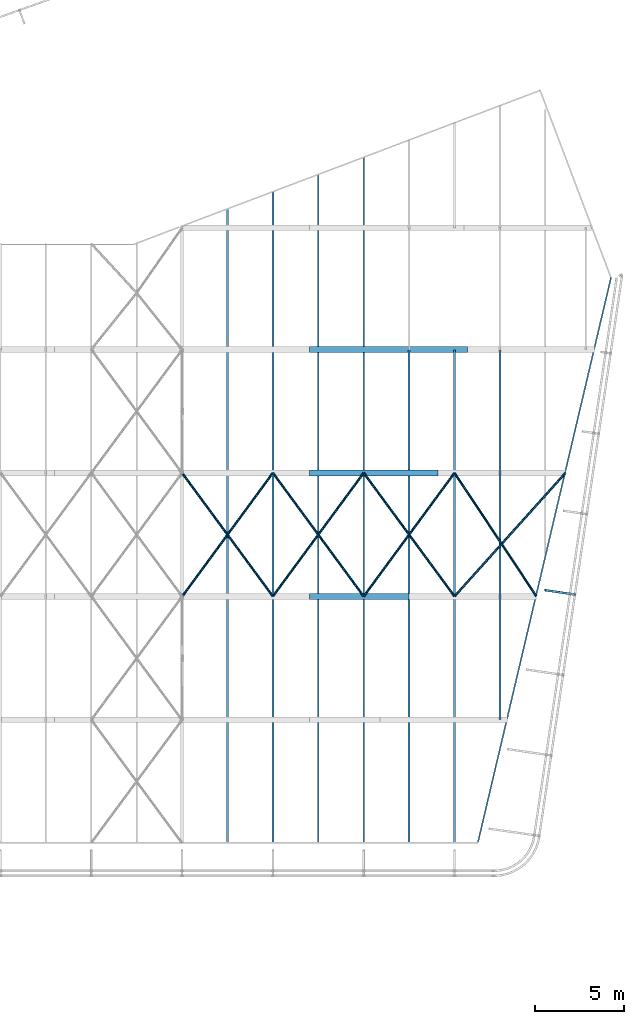
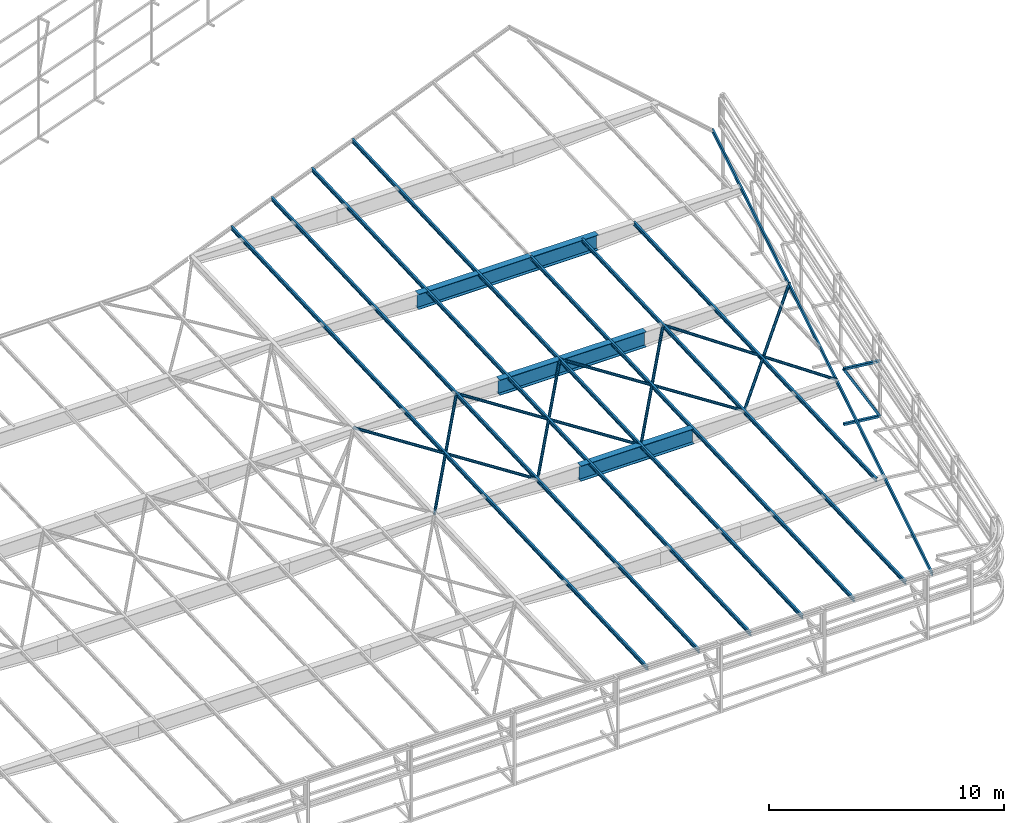
# One storey, part 119 of 215: 21 beams, 1 member, 22 elements without a shape of their own.
"""IFC2X3 building model written with IfcOpenShell, lengths in millimetres."""

from ifc_helpers import new_model, si_unit, frame, origin_with_axes, origin_2d_with_axis, place, context, subcontext, project, spatial, hollow_rectangle, hollow_circle, i_section, u_section, extrude, material, type_object, element, aggregate, save


model = new_model("IFC2X3")

# Units and contexts
model_context = context("Model", 3, precision=1e-05, world=origin_with_axes())
body_context = subcontext(model_context, "Body", "Model", "MODEL_VIEW")
ifc_project = project(units=[si_unit("LENGTHUNIT", "METRE", prefix="MILLI"), si_unit("AREAUNIT", "SQUARE_METRE"), si_unit("VOLUMEUNIT", "CUBIC_METRE"), si_unit("MASSUNIT", "GRAM", prefix="KILO"), si_unit("TIMEUNIT", "SECOND"), si_unit("PLANEANGLEUNIT", "RADIAN"), si_unit("SOLIDANGLEUNIT", "STERADIAN"), si_unit("THERMODYNAMICTEMPERATUREUNIT", "DEGREE_CELSIUS"), si_unit("LUMINOUSINTENSITYUNIT", "LUMEN")], contexts=[model_context])

# Site, building, storey
site_placement = place(None, origin_with_axes())
site = spatial("IfcSite", under=ifc_project, at=site_placement, CompositionType="ELEMENT")
building_placement = place(site_placement, origin_with_axes())
building = spatial("IfcBuilding", under=site, at=building_placement, Name="Undefined", CompositionType="ELEMENT")
storey_placement = place(building_placement, origin_with_axes())
storey = spatial("IfcBuildingStorey", under=building, at=storey_placement, Name="Undefined", CompositionType="ELEMENT", Elevation=0.0)

# Assembly, beam
assembly_1_placement = place(storey_placement, origin_with_axes())
assembly_1 = element("IfcElementAssembly", 1, at=assembly_1_placement, inside=storey, Name="Steel Assembly", AssemblyPlace="NOTDEFINED", PredefinedType="RIGID_FRAME")
ifc_material_1 = material(Name="STEEL/S275JR")
beam_type_1 = type_object("IfcBeamType", PredefinedType="NOTDEFINED")
beam_1_placement = place(assembly_1_placement, frame((149848.417768637, 49115.4753493868, 3598.88504869538), z_axis=(0.0, 0.0, 1.0), x_axis=(0.989265205872398, -0.14613128498115, 0.0)))
beam_1 = element("IfcBeam", 2, at=beam_1_placement, type_object=beam_type_1, material=ifc_material_1, Name="LISSE", context=body_context, shape_type="SweptSolid", body=[
    extrude(hollow_rectangle(XDim=120.0, YDim=120.0, WallThickness=4.0, InnerFilletRadius=4.0, OuterFilletRadius=8.0, at=origin_2d_with_axis()), frame((1661.04869116714, 0.0, 4.54747328902668e-13), z_axis=(-1.0, 0.0, 0.0), x_axis=(-6.93889390390723e-18, -1.0, -3.46944695195361e-18)), (0.0, 0.0, 1.0), 1661.0),
])
aggregate(assembly_1, [beam_1])

assembly_2_placement = place(storey_placement, origin_with_axes())
assembly_2 = element("IfcElementAssembly", 3, at=assembly_2_placement, inside=storey, Name="Steel Assembly", AssemblyPlace="NOTDEFINED", PredefinedType="RIGID_FRAME")
beam_2_placement = place(assembly_2_placement, frame((149848.404628502, 49115.3864259724, 729.379387953734), z_axis=(0.0, 0.0, 1.0), x_axis=(0.989265368205486, -0.146130186030352, 0.0)))
beam_2 = element("IfcBeam", 4, at=beam_2_placement, type_object=beam_type_1, material=ifc_material_1, Name="LISSE", context=body_context, shape_type="SweptSolid", body=[
    extrude(hollow_rectangle(XDim=120.0, YDim=120.0, WallThickness=4.0, InnerFilletRadius=4.0, OuterFilletRadius=8.0, at=origin_2d_with_axis()), frame((1661.0487780215, 1.45980185933265e-11, -1.13686837721616e-13), z_axis=(-1.0, 0.0, 0.0), x_axis=(-6.93889390390723e-18, -1.0, -3.46944695195361e-18)), (0.0, 0.0, 1.0), 1661.0),
])
aggregate(assembly_2, [beam_2])

assembly_3_placement = place(storey_placement, origin_with_axes())
assembly_3 = element("IfcElementAssembly", 5, at=assembly_3_placement, inside=storey, Name="Steel Assembly", AssemblyPlace="NOTDEFINED", PredefinedType="RIGID_FRAME")
beam_type_2 = type_object("IfcBeamType", Name="UPE200", PredefinedType="NOTDEFINED")
beam_3_placement = place(assembly_3_placement, frame((153523.006896876, 66618.6132251194, 4099.5955868735), z_axis=(-0.00910974699815816, -0.0386613779921473, 0.999210843796932), x_axis=(-0.229167306085802, -0.972576298364141, -0.0397201420148716)))
beam_3 = element("IfcBeam", 6, at=beam_3_placement, type_object=beam_type_2, material=ifc_material_1, ObjectType="UPE200", context=body_context, shape_type="SweptSolid", body=[
    extrude(u_section(Depth=200.0, FlangeWidth=80.0, WebThickness=6.0, FlangeThickness=11.0, FilletRadius=13.0, at=origin_2d_with_axis()), frame((32491.2733667673, 2.85357143171447e-11, 7.12462912508487e-13), z_axis=(-1.0, 0.0, 0.0), x_axis=(-6.93889390390723e-18, -1.0, -3.46944695195361e-18)), (0.0, 0.0, 1.0), 32491.3),
])
aggregate(assembly_3, [beam_3])

assembly_4_placement = place(storey_placement, origin_with_axes())
assembly_4 = element("IfcElementAssembly", 7, at=assembly_4_placement, inside=storey, Name="Steel Assembly", AssemblyPlace="NOTDEFINED", PredefinedType="RIGID_FRAME")
beam_type_3 = type_object("IfcBeamType", Name="IPE200", PredefinedType="NOTDEFINED")
beam_4_placement = place(assembly_4_placement, frame((147305.010290178, 41879.8230150658, 3106.10668890624), z_axis=(-2.1980000026525e-06, -0.0399625230126959, 0.999201179317573), x_axis=(0.0, 0.999201183199638, 0.0399624260079844)))
beam_4 = element("IfcBeam", 8, at=beam_4_placement, type_object=beam_type_3, material=ifc_material_1, ObjectType="IPE200", context=body_context, shape_type="SweptSolid", body=[
    extrude(i_section(OverallWidth=100.0, OverallDepth=200.0, WebThickness=5.599999905, FlangeThickness=8.5, FilletRadius=12.0, at=origin_2d_with_axis()), frame((20671.8586044957, 0.0, 0.0), z_axis=(-1.0, 0.0, 0.0), x_axis=(-6.93889390390723e-18, -1.0, -3.46944695195361e-18)), (0.0, 0.0, 1.0), 20671.9),
])
aggregate(assembly_4, [beam_4])

assembly_5_placement = place(storey_placement, origin_with_axes())
assembly_5 = element("IfcElementAssembly", 9, at=assembly_5_placement, inside=storey, Name="Steel Assembly", AssemblyPlace="NOTDEFINED", PredefinedType="RIGID_FRAME")
beam_5_placement = place(assembly_5_placement, frame((132065.011766524, 34986.5206418522, 2830.38010798258), z_axis=(-2.1980000026525e-06, -0.0399625230126959, 0.999201179317573), x_axis=(0.0, 0.999201183199638, 0.0399624260079844)))
beam_5 = element("IfcBeam", 10, at=beam_5_placement, type_object=beam_type_3, material=ifc_material_1, ObjectType="IPE200", context=body_context, shape_type="SweptSolid", body=[
    extrude(i_section(OverallWidth=100.0, OverallDepth=200.0, WebThickness=5.599999905, FlangeThickness=8.5, FilletRadius=12.0, at=origin_2d_with_axis()), frame((35488.6849729297, 9.39377669587501e-19, -4.73625895259578e-13), z_axis=(-1.0, 0.0, 0.0), x_axis=(-6.93889390390723e-18, -1.0, -3.46944695195361e-18)), (0.0, 0.0, 1.0), 35488.7),
])
aggregate(assembly_5, [beam_5])

assembly_6_placement = place(storey_placement, origin_with_axes())
assembly_6 = element("IfcElementAssembly", 11, at=assembly_6_placement, inside=storey, Name="Steel Assembly", AssemblyPlace="NOTDEFINED", PredefinedType="RIGID_FRAME")
beam_6_placement = place(assembly_6_placement, frame((134605.01152048, 34986.520420466, 2830.38564341709), z_axis=(-2.1980000026525e-06, -0.0399625230126959, 0.999201179317573), x_axis=(0.0, 0.999201183199638, 0.0399624260079844)))
beam_6 = element("IfcBeam", 12, at=beam_6_placement, type_object=beam_type_3, material=ifc_material_1, ObjectType="IPE200", context=body_context, shape_type="SweptSolid", body=[
    extrude(i_section(OverallWidth=100.0, OverallDepth=200.0, WebThickness=5.599999905, FlangeThickness=8.5, FilletRadius=12.0, at=origin_2d_with_axis()), frame((36453.8469323161, 9.64925293932403e-19, -2.52949376252616e-13), z_axis=(-1.0, 0.0, 0.0), x_axis=(-6.93889390390723e-18, -1.0, -3.46944695195361e-18)), (0.0, 0.0, 1.0), 36453.8),
])
aggregate(assembly_6, [beam_6])

assembly_7_placement = place(storey_placement, origin_with_axes())
assembly_7 = element("IfcElementAssembly", 13, at=assembly_7_placement, inside=storey, Name="Steel Assembly", AssemblyPlace="NOTDEFINED", PredefinedType="RIGID_FRAME")
beam_7_placement = place(assembly_7_placement, frame((137145.011274437, 34986.5201990798, 2830.39117885161), z_axis=(-2.1980000026525e-06, -0.0399625230126959, 0.999201179317573), x_axis=(0.0, 0.999201183199638, 0.0399624260079844)))
beam_7 = element("IfcBeam", 14, at=beam_7_placement, type_object=beam_type_3, material=ifc_material_1, ObjectType="IPE200", context=body_context, shape_type="SweptSolid", body=[
    extrude(i_section(OverallWidth=100.0, OverallDepth=200.0, WebThickness=5.599999905, FlangeThickness=8.5, FilletRadius=12.0, at=origin_2d_with_axis()), frame((37419.0091151783, 9.90472924192657e-19, -5.1929306847912e-13), z_axis=(-1.0, 0.0, 0.0), x_axis=(-6.93889390390723e-18, -1.0, -3.46944695195361e-18)), (0.0, 0.0, 1.0), 37419.0),
])
aggregate(assembly_7, [beam_7])

assembly_8_placement = place(storey_placement, origin_with_axes())
assembly_8 = element("IfcElementAssembly", 15, at=assembly_8_placement, inside=storey, Name="Steel Assembly", AssemblyPlace="NOTDEFINED", PredefinedType="RIGID_FRAME")
beam_8_placement = place(assembly_8_placement, frame((139685.011028393, 34986.5199776936, 2830.39671428613), z_axis=(-2.1980000026525e-06, -0.0399625230126959, 0.999201179317573), x_axis=(0.0, 0.999201183199638, 0.0399624260079844)))
beam_8 = element("IfcBeam", 16, at=beam_8_placement, type_object=beam_type_3, material=ifc_material_1, ObjectType="IPE200", context=body_context, shape_type="SweptSolid", body=[
    extrude(i_section(OverallWidth=100.0, OverallDepth=200.0, WebThickness=5.599999905, FlangeThickness=8.5, FilletRadius=12.0, at=origin_2d_with_axis()), frame((38380.4139054477, 2.91038319806153e-11, -9.87382591042359e-13), z_axis=(-1.0, 0.0, 0.0), x_axis=(-6.93889390390723e-18, -1.0, -3.46944695195361e-18)), (0.0, 0.0, 1.0), 38380.4),
])
aggregate(assembly_8, [beam_8])

assembly_9_placement = place(storey_placement, origin_with_axes())
assembly_9 = element("IfcElementAssembly", 17, at=assembly_9_placement, inside=storey, Name="Steel Assembly", AssemblyPlace="NOTDEFINED", PredefinedType="RIGID_FRAME")
beam_9_placement = place(assembly_9_placement, frame((142225.010782347, 34986.5197563072, 2830.40224972059), z_axis=(-2.1980000026525e-06, -0.0399625230126959, 0.999201179317573), x_axis=(0.0, 0.999201183199638, 0.0399624260079844)))
beam_9 = element("IfcBeam", 18, at=beam_9_placement, type_object=beam_type_3, material=ifc_material_1, ObjectType="IPE200", context=body_context, shape_type="SweptSolid", body=[
    extrude(i_section(OverallWidth=100.0, OverallDepth=200.0, WebThickness=5.599999905, FlangeThickness=8.5, FilletRadius=12.0, at=origin_2d_with_axis()), frame((27570.6731950585, 3.64894821471805e-19, -6.46057327046274e-13), z_axis=(-1.0, 0.0, 0.0), x_axis=(-6.93889390390723e-18, -1.0, -3.46944695195361e-18)), (0.0, 0.0, 1.0), 27570.7),
])
aggregate(assembly_9, [beam_9])

assembly_10_placement = place(storey_placement, origin_with_axes())
assembly_10 = element("IfcElementAssembly", 19, at=assembly_10_placement, inside=storey, Name="Steel Assembly", AssemblyPlace="NOTDEFINED", PredefinedType="RIGID_FRAME")
beam_10_placement = place(assembly_10_placement, frame((144765.010536303, 34986.5195349212, 2830.40778515512), z_axis=(-2.1980000026525e-06, -0.0399625230126959, 0.999201179317573), x_axis=(0.0, 0.999201183199638, 0.0399624260079844)))
beam_10 = element("IfcBeam", 20, at=beam_10_placement, type_object=beam_type_3, material=ifc_material_1, ObjectType="IPE200", context=body_context, shape_type="SweptSolid", body=[
    extrude(i_section(OverallWidth=100.0, OverallDepth=200.0, WebThickness=5.599999905, FlangeThickness=8.5, FilletRadius=12.0, at=origin_2d_with_axis()), frame((27594.0247627321, 1.09561163068993e-18, -8.37691371307238e-13), z_axis=(-1.0, 0.0, 0.0), x_axis=(-6.93889390390723e-18, -1.0, -3.46944695195361e-18)), (0.0, 0.0, 1.0), 27594.0),
])
aggregate(assembly_10, [beam_10])

assembly_11_placement = place(storey_placement, origin_with_axes())
assembly_11 = element("IfcElementAssembly", 21, at=assembly_11_placement, inside=storey, Name="Steel Assembly", AssemblyPlace="NOTDEFINED", PredefinedType="RIGID_FRAME")
ifc_material_2 = material(Name="STEEL/S235JR")
beam_type_4 = type_object("IfcBeamType", PredefinedType="NOTDEFINED")
beam_11_placement = place(assembly_11_placement, frame((144765.10174132, 55678.0425896527, 3688.12649124559), z_axis=(-0.00130876199984048, -0.040829212995003, 0.999165282877781), x_axis=(0.552536292186865, -0.832823037281657, -0.0333081730112646)))
beam_11 = element("IfcBeam", 22, at=beam_11_placement, type_object=beam_type_4, material=ifc_material_2, context=body_context, shape_type="SweptSolid", body=[
    extrude(hollow_circle(Radius=69.84999845, WallThickness=8.0, at=origin_2d_with_axis()), frame((8292.95264592781, -2.89743566399732e-11, -4.54747350886464e-13), z_axis=(-1.0, 0.0, 0.0), x_axis=(-6.93889390390723e-18, -1.0, -3.46944695195361e-18)), (0.0, 0.0, 1.0), 8293.0),
])
aggregate(assembly_11, [beam_11])

assembly_12_placement = place(storey_placement, origin_with_axes())
assembly_12 = element("IfcElementAssembly", 23, at=assembly_12_placement, inside=storey, Name="Steel Assembly", AssemblyPlace="NOTDEFINED", PredefinedType="RIGID_FRAME")
beam_12_placement = place(assembly_12_placement, frame((144764.963470766, 48771.185252496, 3411.89099646788), z_axis=(0.00067066600027759, -0.0405649540173424, 0.999176678427137), x_axis=(0.668265007232305, 0.743329027258397, 0.0297294020103346)))
beam_12 = element("IfcBeam", 24, at=beam_12_placement, type_object=beam_type_4, material=ifc_material_2, context=body_context, shape_type="SweptSolid", body=[
    extrude(hollow_circle(Radius=69.84999845, WallThickness=8.0, at=origin_2d_with_axis()), frame((9292.13578935082, -1.58875713581247e-12, 4.86985923077966e-13), z_axis=(-1.0, 0.0, 0.0), x_axis=(-6.93889390390723e-18, -1.0, -3.46944695195361e-18)), (0.0, 0.0, 1.0), 9292.1),
])
aggregate(assembly_12, [beam_12])

assembly_13_placement = place(storey_placement, origin_with_axes())
assembly_13 = element("IfcElementAssembly", 25, at=assembly_13_placement, inside=storey, Name="Steel Assembly", AssemblyPlace="NOTDEFINED", PredefinedType="RIGID_FRAME")
beam_13_placement = place(assembly_13_placement, frame((139685.010960287, 55677.9824893561, 3688.11291322925), z_axis=(-2.1980000026525e-06, -0.0399625230126959, 0.999201179317573), x_axis=(0.592192299209503, -0.805153042284844, -0.0322002990113917)))
beam_13 = element("IfcBeam", 26, at=beam_13_placement, type_object=beam_type_4, material=ifc_material_2, context=body_context, shape_type="SweptSolid", body=[
    extrude(hollow_circle(Radius=69.84999845, WallThickness=8.0, at=origin_2d_with_axis()), frame((8578.29376438585, 1.40580531169083e-11, 5.95238703076223e-14), z_axis=(-1.0, 0.0, 0.0), x_axis=(-6.93889390390723e-18, -1.0, -3.46944695195361e-18)), (0.0, 0.0, 1.0), 8578.3),
])
aggregate(assembly_13, [beam_13])

assembly_14_placement = place(storey_placement, origin_with_axes())
assembly_14 = element("IfcElementAssembly", 27, at=assembly_14_placement, inside=storey, Name="Steel Assembly", AssemblyPlace="NOTDEFINED", PredefinedType="RIGID_FRAME")
beam_14_placement = place(assembly_14_placement, frame((139685.010946603, 48771.1436085627, 3411.87821447246), z_axis=(-2.1980000026525e-06, -0.0399625230126959, 0.999201179317573), x_axis=(0.592192300877416, 0.805152937833333, 0.032202879993334)))
beam_14 = element("IfcBeam", 28, at=beam_14_placement, type_object=beam_type_4, material=ifc_material_2, context=body_context, shape_type="SweptSolid", body=[
    extrude(hollow_circle(Radius=69.84999845, WallThickness=8.0, at=origin_2d_with_axis()), frame((8578.29376438585, 1.40580531169083e-11, 5.95238703076223e-14), z_axis=(-1.0, 0.0, 0.0), x_axis=(-6.93889390390723e-18, -1.0, -3.46944695195361e-18)), (0.0, 0.0, 1.0), 8578.3),
])
aggregate(assembly_14, [beam_14])

assembly_15_placement = place(storey_placement, origin_with_axes())
assembly_15 = element("IfcElementAssembly", 29, at=assembly_15_placement, inside=storey, Name="Steel Assembly", AssemblyPlace="NOTDEFINED", PredefinedType="RIGID_FRAME")
beam_15_placement = place(assembly_15_placement, frame((134605.011453609, 55677.9829308202, 3688.10184280854), z_axis=(-2.1980000026525e-06, -0.0399625230126959, 0.999201179317573), x_axis=(0.592192299209503, -0.805153042284844, -0.0322002990113917)))
beam_15 = element("IfcBeam", 30, at=beam_15_placement, type_object=beam_type_4, material=ifc_material_2, context=body_context, shape_type="SweptSolid", body=[
    extrude(hollow_circle(Radius=69.84999845, WallThickness=8.0, at=origin_2d_with_axis()), frame((8578.29376438585, 1.40580531169083e-11, 5.95238703076223e-14), z_axis=(-1.0, 0.0, 0.0), x_axis=(-6.93889390390723e-18, -1.0, -3.46944695195361e-18)), (0.0, 0.0, 1.0), 8578.3),
])
aggregate(assembly_15, [beam_15])

assembly_16_placement = place(storey_placement, origin_with_axes())
assembly_16 = element("IfcElementAssembly", 31, at=assembly_16_placement, inside=storey, Name="Steel Assembly", AssemblyPlace="NOTDEFINED", PredefinedType="RIGID_FRAME")
beam_16_placement = place(assembly_16_placement, frame((134605.011453282, 48771.1440511674, 3411.8671440558), z_axis=(-2.1980000026525e-06, -0.0399625230126959, 0.999201179317573), x_axis=(0.592192300877416, 0.805152937833333, 0.032202879993334)))
beam_16 = element("IfcBeam", 32, at=beam_16_placement, type_object=beam_type_4, material=ifc_material_2, context=body_context, shape_type="SweptSolid", body=[
    extrude(hollow_circle(Radius=69.84999845, WallThickness=8.0, at=origin_2d_with_axis()), frame((8578.29376438585, 1.40580531169083e-11, 5.95238703076223e-14), z_axis=(-1.0, 0.0, 0.0), x_axis=(-6.93889390390723e-18, -1.0, -3.46944695195361e-18)), (0.0, 0.0, 1.0), 8578.3),
])
aggregate(assembly_16, [beam_16])

assembly_17_placement = place(storey_placement, origin_with_axes())
assembly_17 = element("IfcElementAssembly", 33, at=assembly_17_placement, inside=storey, Name="Steel Assembly", AssemblyPlace="NOTDEFINED", PredefinedType="RIGID_FRAME")
beam_17_placement = place(assembly_17_placement, frame((129525.008339668, 55677.9833760359, 3688.09077250695), z_axis=(-2.1980000026525e-06, -0.0399625230126959, 0.999201179317573), x_axis=(0.592192299209503, -0.805153042284844, -0.0322002990113917)))
beam_17 = element("IfcBeam", 34, at=beam_17_placement, type_object=beam_type_4, material=ifc_material_2, context=body_context, shape_type="SweptSolid", body=[
    extrude(hollow_circle(Radius=69.84999845, WallThickness=8.0, at=origin_2d_with_axis()), frame((8578.29590219785, -1.30022486606342e-12, -8.49970816631255e-13), z_axis=(-1.0, 0.0, 0.0), x_axis=(-6.93889390390723e-18, -1.0, -3.46944695195361e-18)), (0.0, 0.0, 1.0), 8578.3),
])
aggregate(assembly_17, [beam_17])

assembly_18_placement = place(storey_placement, origin_with_axes())
assembly_18 = element("IfcElementAssembly", 35, at=assembly_18_placement, inside=storey, Name="Steel Assembly", AssemblyPlace="NOTDEFINED", PredefinedType="RIGID_FRAME")
beam_18_placement = place(assembly_18_placement, frame((129525.007483301, 48755.4093606752, 3411.22675684335), z_axis=(-2.1980000026525e-06, -0.0399625230126959, 0.999201179317573), x_axis=(0.591317581175034, 0.805794539238519, 0.0322285390095398)))
beam_18 = element("IfcBeam", 36, at=beam_18_placement, type_object=beam_type_4, material=ifc_material_2, context=body_context, shape_type="SweptSolid", body=[
    extrude(hollow_circle(Radius=69.84999845, WallThickness=8.0, at=origin_2d_with_axis()), frame((8590.99092008783, 1.45845155269346e-11, 5.96119745239198e-14), z_axis=(-1.0, 0.0, 0.0), x_axis=(-6.93889390390723e-18, -1.0, -3.46944695195361e-18)), (0.0, 0.0, 1.0), 8591.0),
])
aggregate(assembly_18, [beam_18])

assembly_19_placement = place(storey_placement, origin_with_axes())
assembly_19 = element("IfcElementAssembly", 37, at=assembly_19_placement, inside=storey, Name="Steel Assembly", AssemblyPlace="NOTDEFINED", PredefinedType="RIGID_FRAME")
ifc_material_3 = material(Name="STEEL/S355JR")
beam_type_5 = type_object("IfcBeamType", PredefinedType="NOTDEFINED")
beam_19_placement = place(assembly_19_placement, frame((136647.211056429, 62582.2879153396, 3627.69277603435), z_axis=(0.0, 0.0, -1.0), x_axis=(1.0, 0.0, 0.0)))
beam_19 = element("IfcBeam", 38, at=beam_19_placement, type_object=beam_type_5, material=ifc_material_3, Name="POUTRE", context=body_context, shape_type="SweptSolid", body=[
    extrude(i_section(OverallWidth=320.0, OverallDepth=800.0, WebThickness=6.0, FlangeThickness=20.0, FilletRadius=4.2, at=origin_2d_with_axis()), frame((8832.64630339091, 0.0, 0.0), z_axis=(-1.0, 0.0, 0.0), x_axis=(-6.93889390390723e-18, -1.0, -3.46944695195361e-18)), (0.0, 0.0, 1.0), 8832.6),
])
aggregate(assembly_19, [beam_19])

assembly_20_placement = place(storey_placement, origin_with_axes())
assembly_20 = element("IfcElementAssembly", 39, at=assembly_20_placement, inside=storey, Name="Steel Assembly", AssemblyPlace="NOTDEFINED", PredefinedType="RIGID_FRAME")
beam_20_placement = place(assembly_20_placement, frame((136647.210751394, 55675.4699107959, 3351.4208333428), z_axis=(0.0, 0.0, -1.0), x_axis=(0.999999999970953, -7.62200000022255e-06, 0.0)))
beam_20 = element("IfcBeam", 40, at=beam_20_placement, type_object=beam_type_5, material=ifc_material_3, Name="POUTRE", context=body_context, shape_type="SweptSolid", body=[
    extrude(i_section(OverallWidth=320.0, OverallDepth=800.0, WebThickness=6.0, FlangeThickness=20.0, FilletRadius=4.2, at=origin_2d_with_axis()), frame((7205.2529412341, 0.0, 4.54747350886464e-13), z_axis=(-1.0, 0.0, 0.0), x_axis=(-6.93889390390723e-18, -1.0, -3.46944695195361e-18)), (0.0, 0.0, 1.0), 7205.3),
])
aggregate(assembly_20, [beam_20])

assembly_21_placement = place(storey_placement, origin_with_axes())
assembly_21 = element("IfcElementAssembly", 41, at=assembly_21_placement, inside=storey, Name="Steel Assembly", AssemblyPlace="NOTDEFINED", PredefinedType="RIGID_FRAME")
beam_21_placement = place(assembly_21_placement, frame((136647.173930113, 48768.6131385631, 3075.14889114901), z_axis=(0.0, 0.0, -1.0), x_axis=(1.0, 0.0, 0.0)))
beam_21 = element("IfcBeam", 42, at=beam_21_placement, type_object=beam_type_5, material=ifc_material_3, Name="POUTRE", context=body_context, shape_type="SweptSolid", body=[
    extrude(i_section(OverallWidth=320.0, OverallDepth=800.0, WebThickness=6.0, FlangeThickness=20.0, FilletRadius=4.2, at=origin_2d_with_axis()), frame((5577.83663423228, 0.0, 0.0), z_axis=(-1.0, 0.0, 0.0), x_axis=(-6.93889390390723e-18, -1.0, -3.46944695195361e-18)), (0.0, 0.0, 1.0), 5577.8),
])
aggregate(assembly_21, [beam_21])

# Assembly, member
assembly_22_placement = place(storey_placement, origin_with_axes())
assembly_22 = element("IfcElementAssembly", 43, at=assembly_22_placement, inside=storey, Name="Steel Assembly", AssemblyPlace="NOTDEFINED", PredefinedType="RIGID_FRAME")
member_type = type_object("IfcMemberType", PredefinedType="NOTDEFINED")
member_placement = place(assembly_22_placement, frame((151491.613588181, 48872.6577361866, 729.379387928777), z_axis=(0.855975293843718, -0.127739909976674, 0.500987835908529), x_axis=(-0.495605884025915, 0.0732393440038298, 0.865454104045258)))
member = element("IfcMember", 44, at=member_placement, type_object=member_type, material=ifc_material_1, Name="LISSE", context=body_context, shape_type="SweptSolid", body=[
    extrude(hollow_rectangle(XDim=120.0, YDim=120.0, WallThickness=4.0, InnerFilletRadius=4.0, OuterFilletRadius=8.0, at=origin_2d_with_axis()), frame((3315.60697136222, -1.45544315801639e-11, -1.84053160010701e-13), z_axis=(-1.0, 0.0, 0.0), x_axis=(-6.93889390390723e-18, -1.0, -3.46944695195361e-18)), (0.0, 0.0, 1.0), 3315.6),
])
aggregate(assembly_22, [member])

save(model, "model.ifc")
